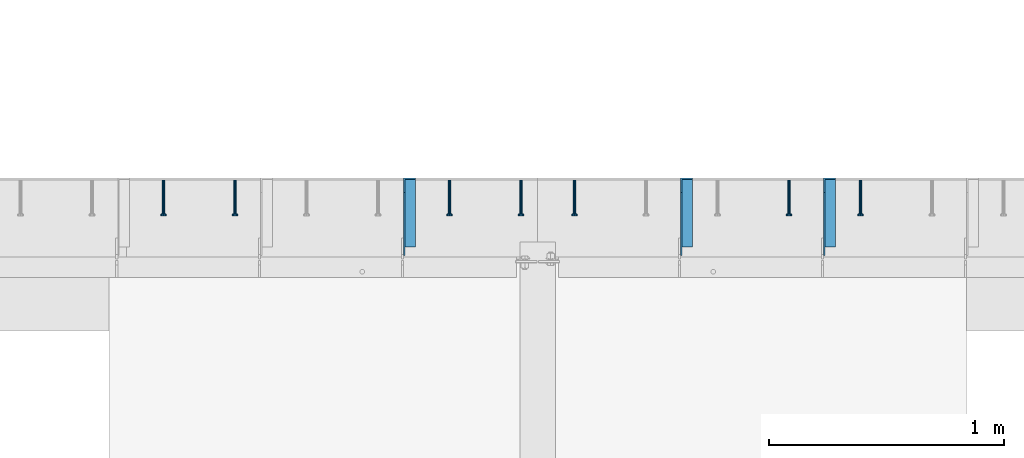
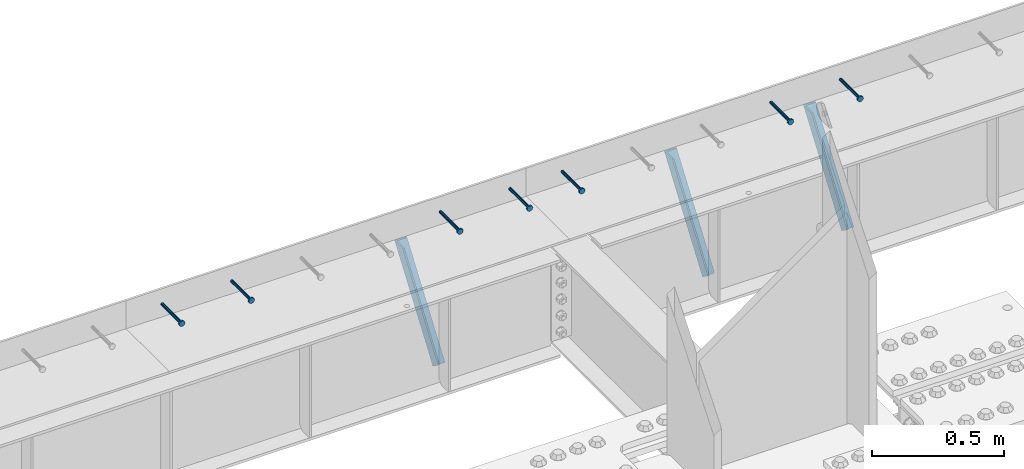
# One storey, part 1347 of 1763: 7 beams, 3 members, 9 elements without a shape of their own.
"""IFC2X3 building model written with IfcOpenShell, lengths in millimetres."""

from ifc_helpers import new_model, si_unit, frame, origin_with_axes, place, context, subcontext, project, spatial, faceted_brep, material, type_object, element, aggregate, save


model = new_model("IFC2X3")

# Units and contexts
model_context = context("Model", 3, precision=1e-05, world=origin_with_axes())
body_context = subcontext(model_context, "Body", "Model", "MODEL_VIEW")
ifc_project = project(units=[si_unit("LENGTHUNIT", "METRE", prefix="MILLI"), si_unit("AREAUNIT", "SQUARE_METRE"), si_unit("VOLUMEUNIT", "CUBIC_METRE"), si_unit("MASSUNIT", "GRAM", prefix="KILO"), si_unit("TIMEUNIT", "SECOND"), si_unit("PLANEANGLEUNIT", "RADIAN"), si_unit("SOLIDANGLEUNIT", "STERADIAN"), si_unit("THERMODYNAMICTEMPERATUREUNIT", "DEGREE_CELSIUS"), si_unit("LUMINOUSINTENSITYUNIT", "LUMEN")], contexts=[model_context])

# Site, building, storey
site_placement = place(None, origin_with_axes())
site = spatial("IfcSite", under=ifc_project, at=site_placement, CompositionType="ELEMENT")
building_placement = place(site_placement, origin_with_axes())
building = spatial("IfcBuilding", under=site, at=building_placement, Name="Undefined", CompositionType="ELEMENT")
storey_placement = place(building_placement, origin_with_axes())
storey = spatial("IfcBuildingStorey", under=building, at=storey_placement, Name="Undefined", CompositionType="ELEMENT", Elevation=0.0)

# Assembly, beam
assembly_1_placement = place(storey_placement, origin_with_axes())
assembly_1 = element("IfcElementAssembly", 1, at=assembly_1_placement, inside=storey, Name="HEADED STUD ANCHOR", AssemblyPlace="NOTDEFINED", PredefinedType="RIGID_FRAME")
ifc_material_1 = material(Name="STEEL/A108")
beam_type = type_object("IfcBeamType", PredefinedType="NOTDEFINED")
beam_1_placement = place(assembly_1_placement, frame((-60218.0747736983, 53984.5250183106, 5264.23140606069), z_axis=(0.0, 0.0, 1.0), x_axis=(0.0, -1.0, 0.0)))
beam_1 = element("IfcBeam", 2, at=beam_1_placement, type_object=beam_type, material=ifc_material_1, Name="HEADED STUD ANCHOR", context=body_context, shape_type="Brep", body=[
    faceted_brep([(0.0, -3.1800000667572, 5.5), (0.0, -5.5, 3.1800000667572), (141.732000000002, -5.5, 3.1800000667572), (141.732000000002, -3.1800000667572, 5.5), (0.0, -6.34999999999491, 1.45519152283669e-11), (141.732000000002, -6.34999990463257, 0.0), (0.0, -5.5, -3.1800000667572), (141.732000000002, -5.5, -3.1800000667572), (0.0, -3.1800000667572, -5.5), (141.732000000002, -3.1800000667572, -5.5), (0.0, 0.0, -6.34999990463257), (141.732000000002, 0.0, -6.34999990463257), (0.0, 3.1800000667572, -5.5), (141.732000000002, 3.1800000667572, -5.5), (0.0, 5.5, -3.1800000667572), (141.732000000002, 5.5, -3.1800000667572), (0.0, 6.34999999999491, -2.91038304567337e-11), (141.732000000002, 6.34999990463257, 0.0), (0.0, 5.5, 3.1800000667572), (141.732000000002, 5.5, 3.1800000667572), (0.0, 3.1800000667572, 5.5), (141.732000000002, 3.1800000667572, 5.5), (0.0, 0.0, 6.34999990463257), (141.732000000002, 0.0, 6.34999990463257), (144.780000000001, -10.9899997711182, 6.34999990463257), (144.780000000001, -6.34000015258789, 10.9899997711182), (144.780000000001, -12.6999998092651, 0.0), (144.780000000001, -10.9899997711182, -6.34999990463257), (144.780000000001, -6.34000015258789, -10.9899997711182), (144.780000000001, 0.0, -12.6899995803833), (144.780000000001, 6.34000015258789, -10.9899997711182), (144.780000000001, 10.9899997711182, -6.34999990463257), (144.780000000001, 12.6999998092651, 0.0), (144.780000000001, 10.9899997711182, 6.34999990463257), (144.780000000001, 6.34000015258789, 10.9899997711182), (144.780000000001, 0.0, 12.6899995803833), (152.400000000001, -10.9899997711182, 6.34999990463257), (152.400000000001, -6.34000015258789, 10.9899997711182), (152.400000000001, -12.6999998092651, 0.0), (152.400000000001, -10.9899997711182, -6.34999990463257), (152.400000000001, -6.34000015258789, -10.9899997711182), (152.400000000001, 0.0, -12.6899995803833), (152.400000000001, 6.34000015258789, -10.9899997711182), (152.400000000001, 10.9899997711182, -6.34999990463257), (152.400000000001, 12.6999998092651, 0.0), (152.400000000001, 10.9899997711182, 6.34999990463257), (152.400000000001, 6.34000015258789, 10.9899997711182), (152.400000000001, 0.0, 12.6899995803833)], [[[0, 1, 2, 3]], [[1, 4, 5, 2]], [[4, 6, 7, 5]], [[6, 8, 9, 7]], [[8, 10, 11, 9]], [[10, 12, 13, 11]], [[12, 14, 15, 13]], [[14, 16, 17, 15]], [[16, 18, 19, 17]], [[18, 20, 21, 19]], [[20, 22, 23, 21]], [[22, 0, 3, 23]], [[22, 20, 18, 16, 14, 12, 10, 8, 6, 4, 1, 0]], [[3, 2, 24, 25]], [[2, 5, 26, 24]], [[5, 7, 27, 26]], [[7, 9, 28, 27]], [[9, 11, 29, 28]], [[11, 13, 30, 29]], [[13, 15, 31, 30]], [[15, 17, 32, 31]], [[17, 19, 33, 32]], [[19, 21, 34, 33]], [[21, 23, 35, 34]], [[23, 3, 25, 35]], [[25, 24, 36, 37]], [[24, 26, 38, 36]], [[26, 27, 39, 38]], [[27, 28, 40, 39]], [[28, 29, 41, 40]], [[29, 30, 42, 41]], [[30, 31, 43, 42]], [[31, 32, 44, 43]], [[32, 33, 45, 44]], [[33, 34, 46, 45]], [[34, 35, 47, 46]], [[35, 25, 37, 47]], [[38, 39, 40, 41, 42, 43, 44, 45, 46, 47, 37, 36]]]),
])
aggregate(assembly_1, [beam_1])

assembly_2_placement = place(storey_placement, origin_with_axes())
assembly_2 = element("IfcElementAssembly", 3, at=assembly_2_placement, inside=storey, Name="HEADED STUD ANCHOR", AssemblyPlace="NOTDEFINED", PredefinedType="RIGID_FRAME")
beam_2_placement = place(assembly_2_placement, frame((-60522.8747736983, 53984.5250183106, 5264.23140606069), z_axis=(0.0, 0.0, 1.0), x_axis=(0.0, -1.0, 0.0)))
beam_2 = element("IfcBeam", 4, at=beam_2_placement, type_object=beam_type, material=ifc_material_1, Name="HEADED STUD ANCHOR", context=body_context, shape_type="Brep", body=[
    faceted_brep([(0.0, -3.1800000667572, 5.5), (0.0, -5.5, 3.1800000667572), (141.732000000002, -5.5, 3.1800000667572), (141.732000000002, -3.1800000667572, 5.5), (0.0, -6.34999999999491, 1.45519152283669e-11), (141.732000000002, -6.34999990463257, 0.0), (0.0, -5.5, -3.1800000667572), (141.732000000002, -5.5, -3.1800000667572), (0.0, -3.1800000667572, -5.5), (141.732000000002, -3.1800000667572, -5.5), (0.0, 0.0, -6.34999990463257), (141.732000000002, 0.0, -6.34999990463257), (0.0, 3.1800000667572, -5.5), (141.732000000002, 3.1800000667572, -5.5), (0.0, 5.5, -3.1800000667572), (141.732000000002, 5.5, -3.1800000667572), (0.0, 6.34999999999491, -2.91038304567337e-11), (141.732000000002, 6.34999990463257, 0.0), (0.0, 5.5, 3.1800000667572), (141.732000000002, 5.5, 3.1800000667572), (0.0, 3.1800000667572, 5.5), (141.732000000002, 3.1800000667572, 5.5), (0.0, 0.0, 6.34999990463257), (141.732000000002, 0.0, 6.34999990463257), (144.780000000001, -10.9899997711182, 6.34999990463257), (144.780000000001, -6.34000015258789, 10.9899997711182), (144.780000000001, -12.6999998092651, 0.0), (144.780000000001, -10.9899997711182, -6.34999990463257), (144.780000000001, -6.34000015258789, -10.9899997711182), (144.780000000001, 0.0, -12.6899995803833), (144.780000000001, 6.34000015258789, -10.9899997711182), (144.780000000001, 10.9899997711182, -6.34999990463257), (144.780000000001, 12.6999998092651, 0.0), (144.780000000001, 10.9899997711182, 6.34999990463257), (144.780000000001, 6.34000015258789, 10.9899997711182), (144.780000000001, 0.0, 12.6899995803833), (152.400000000001, -10.9899997711182, 6.34999990463257), (152.400000000001, -6.34000015258789, 10.9899997711182), (152.400000000001, -12.6999998092651, 0.0), (152.400000000001, -10.9899997711182, -6.34999990463257), (152.400000000001, -6.34000015258789, -10.9899997711182), (152.400000000001, 0.0, -12.6899995803833), (152.400000000001, 6.34000015258789, -10.9899997711182), (152.400000000001, 10.9899997711182, -6.34999990463257), (152.400000000001, 12.6999998092651, 0.0), (152.400000000001, 10.9899997711182, 6.34999990463257), (152.400000000001, 6.34000015258789, 10.9899997711182), (152.400000000001, 0.0, 12.6899995803833)], [[[0, 1, 2, 3]], [[1, 4, 5, 2]], [[4, 6, 7, 5]], [[6, 8, 9, 7]], [[8, 10, 11, 9]], [[10, 12, 13, 11]], [[12, 14, 15, 13]], [[14, 16, 17, 15]], [[16, 18, 19, 17]], [[18, 20, 21, 19]], [[20, 22, 23, 21]], [[22, 0, 3, 23]], [[22, 20, 18, 16, 14, 12, 10, 8, 6, 4, 1, 0]], [[3, 2, 24, 25]], [[2, 5, 26, 24]], [[5, 7, 27, 26]], [[7, 9, 28, 27]], [[9, 11, 29, 28]], [[11, 13, 30, 29]], [[13, 15, 31, 30]], [[15, 17, 32, 31]], [[17, 19, 33, 32]], [[19, 21, 34, 33]], [[21, 23, 35, 34]], [[23, 3, 25, 35]], [[25, 24, 36, 37]], [[24, 26, 38, 36]], [[26, 27, 39, 38]], [[27, 28, 40, 39]], [[28, 29, 41, 40]], [[29, 30, 42, 41]], [[30, 31, 43, 42]], [[31, 32, 44, 43]], [[32, 33, 45, 44]], [[33, 34, 46, 45]], [[34, 35, 47, 46]], [[35, 25, 37, 47]], [[38, 39, 40, 41, 42, 43, 44, 45, 46, 47, 37, 36]]]),
])
aggregate(assembly_2, [beam_2])

assembly_3_placement = place(storey_placement, origin_with_axes())
assembly_3 = element("IfcElementAssembly", 5, at=assembly_3_placement, inside=storey, Name="HEADED STUD ANCHOR", AssemblyPlace="NOTDEFINED", PredefinedType="RIGID_FRAME")
beam_3_placement = place(assembly_3_placement, frame((-61437.2747736983, 53984.5250183106, 5264.23140606069), z_axis=(0.0, 0.0, 1.0), x_axis=(0.0, -1.0, 0.0)))
beam_3 = element("IfcBeam", 6, at=beam_3_placement, type_object=beam_type, material=ifc_material_1, Name="HEADED STUD ANCHOR", context=body_context, shape_type="Brep", body=[
    faceted_brep([(0.0, -3.1800000667572, 5.5), (0.0, -5.5, 3.1800000667572), (141.732000000002, -5.5, 3.1800000667572), (141.732000000002, -3.1800000667572, 5.5), (0.0, -6.34999999999491, 1.45519152283669e-11), (141.732000000002, -6.34999990463257, 0.0), (0.0, -5.5, -3.1800000667572), (141.732000000002, -5.5, -3.1800000667572), (0.0, -3.1800000667572, -5.5), (141.732000000002, -3.1800000667572, -5.5), (0.0, 0.0, -6.34999990463257), (141.732000000002, 0.0, -6.34999990463257), (0.0, 3.1800000667572, -5.5), (141.732000000002, 3.1800000667572, -5.5), (0.0, 5.5, -3.1800000667572), (141.732000000002, 5.5, -3.1800000667572), (0.0, 6.34999999999491, -2.91038304567337e-11), (141.732000000002, 6.34999990463257, 0.0), (0.0, 5.5, 3.1800000667572), (141.732000000002, 5.5, 3.1800000667572), (0.0, 3.1800000667572, 5.5), (141.732000000002, 3.1800000667572, 5.5), (0.0, 0.0, 6.34999990463257), (141.732000000002, 0.0, 6.34999990463257), (144.780000000001, -10.9899997711182, 6.34999990463257), (144.780000000001, -6.34000015258789, 10.9899997711182), (144.780000000001, -12.6999998092651, 0.0), (144.780000000001, -10.9899997711182, -6.34999990463257), (144.780000000001, -6.34000015258789, -10.9899997711182), (144.780000000001, 0.0, -12.6899995803833), (144.780000000001, 6.34000015258789, -10.9899997711182), (144.780000000001, 10.9899997711182, -6.34999990463257), (144.780000000001, 12.6999998092651, 0.0), (144.780000000001, 10.9899997711182, 6.34999990463257), (144.780000000001, 6.34000015258789, 10.9899997711182), (144.780000000001, 0.0, 12.6899995803833), (152.400000000001, -10.9899997711182, 6.34999990463257), (152.400000000001, -6.34000015258789, 10.9899997711182), (152.400000000001, -12.6999998092651, 0.0), (152.400000000001, -10.9899997711182, -6.34999990463257), (152.400000000001, -6.34000015258789, -10.9899997711182), (152.400000000001, 0.0, -12.6899995803833), (152.400000000001, 6.34000015258789, -10.9899997711182), (152.400000000001, 10.9899997711182, -6.34999990463257), (152.400000000001, 12.6999998092651, 0.0), (152.400000000001, 10.9899997711182, 6.34999990463257), (152.400000000001, 6.34000015258789, 10.9899997711182), (152.400000000001, 0.0, 12.6899995803833)], [[[0, 1, 2, 3]], [[1, 4, 5, 2]], [[4, 6, 7, 5]], [[6, 8, 9, 7]], [[8, 10, 11, 9]], [[10, 12, 13, 11]], [[12, 14, 15, 13]], [[14, 16, 17, 15]], [[16, 18, 19, 17]], [[18, 20, 21, 19]], [[20, 22, 23, 21]], [[22, 0, 3, 23]], [[22, 20, 18, 16, 14, 12, 10, 8, 6, 4, 1, 0]], [[3, 2, 24, 25]], [[2, 5, 26, 24]], [[5, 7, 27, 26]], [[7, 9, 28, 27]], [[9, 11, 29, 28]], [[11, 13, 30, 29]], [[13, 15, 31, 30]], [[15, 17, 32, 31]], [[17, 19, 33, 32]], [[19, 21, 34, 33]], [[21, 23, 35, 34]], [[23, 3, 25, 35]], [[25, 24, 36, 37]], [[24, 26, 38, 36]], [[26, 27, 39, 38]], [[27, 28, 40, 39]], [[28, 29, 41, 40]], [[29, 30, 42, 41]], [[30, 31, 43, 42]], [[31, 32, 44, 43]], [[32, 33, 45, 44]], [[33, 34, 46, 45]], [[34, 35, 47, 46]], [[35, 25, 37, 47]], [[38, 39, 40, 41, 42, 43, 44, 45, 46, 47, 37, 36]]]),
])
aggregate(assembly_3, [beam_3])

assembly_4_placement = place(storey_placement, origin_with_axes())
assembly_4 = element("IfcElementAssembly", 7, at=assembly_4_placement, inside=storey, Name="HEADED STUD ANCHOR", AssemblyPlace="NOTDEFINED", PredefinedType="RIGID_FRAME")
beam_4_placement = place(assembly_4_placement, frame((-61665.8747736983, 53984.5250183106, 5264.23140606069), z_axis=(0.0, 0.0, 1.0), x_axis=(0.0, -1.0, 0.0)))
beam_4 = element("IfcBeam", 8, at=beam_4_placement, type_object=beam_type, material=ifc_material_1, Name="HEADED STUD ANCHOR", context=body_context, shape_type="Brep", body=[
    faceted_brep([(0.0, -3.1800000667572, 5.5), (0.0, -5.5, 3.1800000667572), (141.732000000002, -5.5, 3.1800000667572), (141.732000000002, -3.1800000667572, 5.5), (0.0, -6.34999999999491, 1.45519152283669e-11), (141.732000000002, -6.34999990463257, 0.0), (0.0, -5.5, -3.1800000667572), (141.732000000002, -5.5, -3.1800000667572), (0.0, -3.1800000667572, -5.5), (141.732000000002, -3.1800000667572, -5.5), (0.0, 0.0, -6.34999990463257), (141.732000000002, 0.0, -6.34999990463257), (0.0, 3.1800000667572, -5.5), (141.732000000002, 3.1800000667572, -5.5), (0.0, 5.5, -3.1800000667572), (141.732000000002, 5.5, -3.1800000667572), (0.0, 6.34999999999491, -2.91038304567337e-11), (141.732000000002, 6.34999990463257, 0.0), (0.0, 5.5, 3.1800000667572), (141.732000000002, 5.5, 3.1800000667572), (0.0, 3.1800000667572, 5.5), (141.732000000002, 3.1800000667572, 5.5), (0.0, 0.0, 6.34999990463257), (141.732000000002, 0.0, 6.34999990463257), (144.780000000001, -10.9899997711182, 6.34999990463257), (144.780000000001, -6.34000015258789, 10.9899997711182), (144.780000000001, -12.6999998092651, 0.0), (144.780000000001, -10.9899997711182, -6.34999990463257), (144.780000000001, -6.34000015258789, -10.9899997711182), (144.780000000001, 0.0, -12.6899995803833), (144.780000000001, 6.34000015258789, -10.9899997711182), (144.780000000001, 10.9899997711182, -6.34999990463257), (144.780000000001, 12.6999998092651, 0.0), (144.780000000001, 10.9899997711182, 6.34999990463257), (144.780000000001, 6.34000015258789, 10.9899997711182), (144.780000000001, 0.0, 12.6899995803833), (152.400000000001, -10.9899997711182, 6.34999990463257), (152.400000000001, -6.34000015258789, 10.9899997711182), (152.400000000001, -12.6999998092651, 0.0), (152.400000000001, -10.9899997711182, -6.34999990463257), (152.400000000001, -6.34000015258789, -10.9899997711182), (152.400000000001, 0.0, -12.6899995803833), (152.400000000001, 6.34000015258789, -10.9899997711182), (152.400000000001, 10.9899997711182, -6.34999990463257), (152.400000000001, 12.6999998092651, 0.0), (152.400000000001, 10.9899997711182, 6.34999990463257), (152.400000000001, 6.34000015258789, 10.9899997711182), (152.400000000001, 0.0, 12.6899995803833)], [[[0, 1, 2, 3]], [[1, 4, 5, 2]], [[4, 6, 7, 5]], [[6, 8, 9, 7]], [[8, 10, 11, 9]], [[10, 12, 13, 11]], [[12, 14, 15, 13]], [[14, 16, 17, 15]], [[16, 18, 19, 17]], [[18, 20, 21, 19]], [[20, 22, 23, 21]], [[22, 0, 3, 23]], [[22, 20, 18, 16, 14, 12, 10, 8, 6, 4, 1, 0]], [[3, 2, 24, 25]], [[2, 5, 26, 24]], [[5, 7, 27, 26]], [[7, 9, 28, 27]], [[9, 11, 29, 28]], [[11, 13, 30, 29]], [[13, 15, 31, 30]], [[15, 17, 32, 31]], [[17, 19, 33, 32]], [[19, 21, 34, 33]], [[21, 23, 35, 34]], [[23, 3, 25, 35]], [[25, 24, 36, 37]], [[24, 26, 38, 36]], [[26, 27, 39, 38]], [[27, 28, 40, 39]], [[28, 29, 41, 40]], [[29, 30, 42, 41]], [[30, 31, 43, 42]], [[31, 32, 44, 43]], [[32, 33, 45, 44]], [[33, 34, 46, 45]], [[34, 35, 47, 46]], [[35, 25, 37, 47]], [[38, 39, 40, 41, 42, 43, 44, 45, 46, 47, 37, 36]]]),
])
aggregate(assembly_4, [beam_4])

assembly_5_placement = place(storey_placement, origin_with_axes())
assembly_5 = element("IfcElementAssembly", 9, at=assembly_5_placement, inside=storey, Name="HEADED STUD ANCHOR", AssemblyPlace="NOTDEFINED", PredefinedType="RIGID_FRAME")
beam_5_placement = place(assembly_5_placement, frame((-61970.6747736984, 53984.5250183106, 5264.23140606069), z_axis=(0.0, 0.0, 1.0), x_axis=(0.0, -1.0, 0.0)))
beam_5 = element("IfcBeam", 10, at=beam_5_placement, type_object=beam_type, material=ifc_material_1, Name="HEADED STUD ANCHOR", context=body_context, shape_type="Brep", body=[
    faceted_brep([(0.0, -3.1800000667572, 5.5), (0.0, -5.5, 3.1800000667572), (141.732000000002, -5.5, 3.1800000667572), (141.732000000002, -3.1800000667572, 5.5), (0.0, -6.34999999999491, 1.45519152283669e-11), (141.732000000002, -6.34999990463257, 0.0), (0.0, -5.5, -3.1800000667572), (141.732000000002, -5.5, -3.1800000667572), (0.0, -3.1800000667572, -5.5), (141.732000000002, -3.1800000667572, -5.5), (0.0, 0.0, -6.34999990463257), (141.732000000002, 0.0, -6.34999990463257), (0.0, 3.1800000667572, -5.5), (141.732000000002, 3.1800000667572, -5.5), (0.0, 5.5, -3.1800000667572), (141.732000000002, 5.5, -3.1800000667572), (0.0, 6.34999999999491, -2.91038304567337e-11), (141.732000000002, 6.34999990463257, 0.0), (0.0, 5.5, 3.1800000667572), (141.732000000002, 5.5, 3.1800000667572), (0.0, 3.1800000667572, 5.5), (141.732000000002, 3.1800000667572, 5.5), (0.0, 0.0, 6.34999990463257), (141.732000000002, 0.0, 6.34999990463257), (144.780000000001, -10.9899997711182, 6.34999990463257), (144.780000000001, -6.34000015258789, 10.9899997711182), (144.780000000001, -12.6999998092651, 0.0), (144.780000000001, -10.9899997711182, -6.34999990463257), (144.780000000001, -6.34000015258789, -10.9899997711182), (144.780000000001, 0.0, -12.6899995803833), (144.780000000001, 6.34000015258789, -10.9899997711182), (144.780000000001, 10.9899997711182, -6.34999990463257), (144.780000000001, 12.6999998092651, 0.0), (144.780000000001, 10.9899997711182, 6.34999990463257), (144.780000000001, 6.34000015258789, 10.9899997711182), (144.780000000001, 0.0, 12.6899995803833), (152.400000000001, -10.9899997711182, 6.34999990463257), (152.400000000001, -6.34000015258789, 10.9899997711182), (152.400000000001, -12.6999998092651, 0.0), (152.400000000001, -10.9899997711182, -6.34999990463257), (152.400000000001, -6.34000015258789, -10.9899997711182), (152.400000000001, 0.0, -12.6899995803833), (152.400000000001, 6.34000015258789, -10.9899997711182), (152.400000000001, 10.9899997711182, -6.34999990463257), (152.400000000001, 12.6999998092651, 0.0), (152.400000000001, 10.9899997711182, 6.34999990463257), (152.400000000001, 6.34000015258789, 10.9899997711182), (152.400000000001, 0.0, 12.6899995803833)], [[[0, 1, 2, 3]], [[1, 4, 5, 2]], [[4, 6, 7, 5]], [[6, 8, 9, 7]], [[8, 10, 11, 9]], [[10, 12, 13, 11]], [[12, 14, 15, 13]], [[14, 16, 17, 15]], [[16, 18, 19, 17]], [[18, 20, 21, 19]], [[20, 22, 23, 21]], [[22, 0, 3, 23]], [[22, 20, 18, 16, 14, 12, 10, 8, 6, 4, 1, 0]], [[3, 2, 24, 25]], [[2, 5, 26, 24]], [[5, 7, 27, 26]], [[7, 9, 28, 27]], [[9, 11, 29, 28]], [[11, 13, 30, 29]], [[13, 15, 31, 30]], [[15, 17, 32, 31]], [[17, 19, 33, 32]], [[19, 21, 34, 33]], [[21, 23, 35, 34]], [[23, 3, 25, 35]], [[25, 24, 36, 37]], [[24, 26, 38, 36]], [[26, 27, 39, 38]], [[27, 28, 40, 39]], [[28, 29, 41, 40]], [[29, 30, 42, 41]], [[30, 31, 43, 42]], [[31, 32, 44, 43]], [[32, 33, 45, 44]], [[33, 34, 46, 45]], [[34, 35, 47, 46]], [[35, 25, 37, 47]], [[38, 39, 40, 41, 42, 43, 44, 45, 46, 47, 37, 36]]]),
])
aggregate(assembly_5, [beam_5])

assembly_6_placement = place(storey_placement, origin_with_axes())
assembly_6 = element("IfcElementAssembly", 11, at=assembly_6_placement, inside=storey, Name="HEADED STUD ANCHOR", AssemblyPlace="NOTDEFINED", PredefinedType="RIGID_FRAME")
beam_6_placement = place(assembly_6_placement, frame((-62885.0747736983, 53984.5250183106, 5264.23140606069), z_axis=(0.0, 0.0, 1.0), x_axis=(0.0, -1.0, 0.0)))
beam_6 = element("IfcBeam", 12, at=beam_6_placement, type_object=beam_type, material=ifc_material_1, Name="HEADED STUD ANCHOR", context=body_context, shape_type="Brep", body=[
    faceted_brep([(0.0, -3.1800000667572, 5.5), (0.0, -5.5, 3.1800000667572), (141.732000000002, -5.5, 3.1800000667572), (141.732000000002, -3.1800000667572, 5.5), (0.0, -6.34999999999491, 1.45519152283669e-11), (141.732000000002, -6.34999990463257, 0.0), (0.0, -5.5, -3.1800000667572), (141.732000000002, -5.5, -3.1800000667572), (0.0, -3.1800000667572, -5.5), (141.732000000002, -3.1800000667572, -5.5), (0.0, 0.0, -6.34999990463257), (141.732000000002, 0.0, -6.34999990463257), (0.0, 3.1800000667572, -5.5), (141.732000000002, 3.1800000667572, -5.5), (0.0, 5.5, -3.1800000667572), (141.732000000002, 5.5, -3.1800000667572), (0.0, 6.34999999999491, -2.91038304567337e-11), (141.732000000002, 6.34999990463257, 0.0), (0.0, 5.5, 3.1800000667572), (141.732000000002, 5.5, 3.1800000667572), (0.0, 3.1800000667572, 5.5), (141.732000000002, 3.1800000667572, 5.5), (0.0, 0.0, 6.34999990463257), (141.732000000002, 0.0, 6.34999990463257), (144.780000000001, -10.9899997711182, 6.34999990463257), (144.780000000001, -6.34000015258789, 10.9899997711182), (144.780000000001, -12.6999998092651, 0.0), (144.780000000001, -10.9899997711182, -6.34999990463257), (144.780000000001, -6.34000015258789, -10.9899997711182), (144.780000000001, 0.0, -12.6899995803833), (144.780000000001, 6.34000015258789, -10.9899997711182), (144.780000000001, 10.9899997711182, -6.34999990463257), (144.780000000001, 12.6999998092651, 0.0), (144.780000000001, 10.9899997711182, 6.34999990463257), (144.780000000001, 6.34000015258789, 10.9899997711182), (144.780000000001, 0.0, 12.6899995803833), (152.400000000001, -10.9899997711182, 6.34999990463257), (152.400000000001, -6.34000015258789, 10.9899997711182), (152.400000000001, -12.6999998092651, 0.0), (152.400000000001, -10.9899997711182, -6.34999990463257), (152.400000000001, -6.34000015258789, -10.9899997711182), (152.400000000001, 0.0, -12.6899995803833), (152.400000000001, 6.34000015258789, -10.9899997711182), (152.400000000001, 10.9899997711182, -6.34999990463257), (152.400000000001, 12.6999998092651, 0.0), (152.400000000001, 10.9899997711182, 6.34999990463257), (152.400000000001, 6.34000015258789, 10.9899997711182), (152.400000000001, 0.0, 12.6899995803833)], [[[0, 1, 2, 3]], [[1, 4, 5, 2]], [[4, 6, 7, 5]], [[6, 8, 9, 7]], [[8, 10, 11, 9]], [[10, 12, 13, 11]], [[12, 14, 15, 13]], [[14, 16, 17, 15]], [[16, 18, 19, 17]], [[18, 20, 21, 19]], [[20, 22, 23, 21]], [[22, 0, 3, 23]], [[22, 20, 18, 16, 14, 12, 10, 8, 6, 4, 1, 0]], [[3, 2, 24, 25]], [[2, 5, 26, 24]], [[5, 7, 27, 26]], [[7, 9, 28, 27]], [[9, 11, 29, 28]], [[11, 13, 30, 29]], [[13, 15, 31, 30]], [[15, 17, 32, 31]], [[17, 19, 33, 32]], [[19, 21, 34, 33]], [[21, 23, 35, 34]], [[23, 3, 25, 35]], [[25, 24, 36, 37]], [[24, 26, 38, 36]], [[26, 27, 39, 38]], [[27, 28, 40, 39]], [[28, 29, 41, 40]], [[29, 30, 42, 41]], [[30, 31, 43, 42]], [[31, 32, 44, 43]], [[32, 33, 45, 44]], [[33, 34, 46, 45]], [[34, 35, 47, 46]], [[35, 25, 37, 47]], [[38, 39, 40, 41, 42, 43, 44, 45, 46, 47, 37, 36]]]),
])
aggregate(assembly_6, [beam_6])

assembly_7_placement = place(storey_placement, origin_with_axes())
assembly_7 = element("IfcElementAssembly", 13, at=assembly_7_placement, inside=storey, Name="HEADED STUD ANCHOR", AssemblyPlace="NOTDEFINED", PredefinedType="RIGID_FRAME")
beam_7_placement = place(assembly_7_placement, frame((-63189.8747736983, 53984.5250183106, 5264.23140606069), z_axis=(0.0, 0.0, 1.0), x_axis=(0.0, -1.0, 0.0)))
beam_7 = element("IfcBeam", 14, at=beam_7_placement, type_object=beam_type, material=ifc_material_1, Name="HEADED STUD ANCHOR", context=body_context, shape_type="Brep", body=[
    faceted_brep([(0.0, -3.1800000667572, 5.5), (0.0, -5.5, 3.1800000667572), (141.732000000002, -5.5, 3.1800000667572), (141.732000000002, -3.1800000667572, 5.5), (0.0, -6.34999999999491, 1.45519152283669e-11), (141.732000000002, -6.34999990463257, 0.0), (0.0, -5.5, -3.1800000667572), (141.732000000002, -5.5, -3.1800000667572), (0.0, -3.1800000667572, -5.5), (141.732000000002, -3.1800000667572, -5.5), (0.0, 0.0, -6.34999990463257), (141.732000000002, 0.0, -6.34999990463257), (0.0, 3.1800000667572, -5.5), (141.732000000002, 3.1800000667572, -5.5), (0.0, 5.5, -3.1800000667572), (141.732000000002, 5.5, -3.1800000667572), (0.0, 6.34999999999491, -2.91038304567337e-11), (141.732000000002, 6.34999990463257, 0.0), (0.0, 5.5, 3.1800000667572), (141.732000000002, 5.5, 3.1800000667572), (0.0, 3.1800000667572, 5.5), (141.732000000002, 3.1800000667572, 5.5), (0.0, 0.0, 6.34999990463257), (141.732000000002, 0.0, 6.34999990463257), (144.780000000001, -10.9899997711182, 6.34999990463257), (144.780000000001, -6.34000015258789, 10.9899997711182), (144.780000000001, -12.6999998092651, 0.0), (144.780000000001, -10.9899997711182, -6.34999990463257), (144.780000000001, -6.34000015258789, -10.9899997711182), (144.780000000001, 0.0, -12.6899995803833), (144.780000000001, 6.34000015258789, -10.9899997711182), (144.780000000001, 10.9899997711182, -6.34999990463257), (144.780000000001, 12.6999998092651, 0.0), (144.780000000001, 10.9899997711182, 6.34999990463257), (144.780000000001, 6.34000015258789, 10.9899997711182), (144.780000000001, 0.0, 12.6899995803833), (152.400000000001, -10.9899997711182, 6.34999990463257), (152.400000000001, -6.34000015258789, 10.9899997711182), (152.400000000001, -12.6999998092651, 0.0), (152.400000000001, -10.9899997711182, -6.34999990463257), (152.400000000001, -6.34000015258789, -10.9899997711182), (152.400000000001, 0.0, -12.6899995803833), (152.400000000001, 6.34000015258789, -10.9899997711182), (152.400000000001, 10.9899997711182, -6.34999990463257), (152.400000000001, 12.6999998092651, 0.0), (152.400000000001, 10.9899997711182, 6.34999990463257), (152.400000000001, 6.34000015258789, 10.9899997711182), (152.400000000001, 0.0, 12.6899995803833)], [[[0, 1, 2, 3]], [[1, 4, 5, 2]], [[4, 6, 7, 5]], [[6, 8, 9, 7]], [[8, 10, 11, 9]], [[10, 12, 13, 11]], [[12, 14, 15, 13]], [[14, 16, 17, 15]], [[16, 18, 19, 17]], [[18, 20, 21, 19]], [[20, 22, 23, 21]], [[22, 0, 3, 23]], [[22, 20, 18, 16, 14, 12, 10, 8, 6, 4, 1, 0]], [[3, 2, 24, 25]], [[2, 5, 26, 24]], [[5, 7, 27, 26]], [[7, 9, 28, 27]], [[9, 11, 29, 28]], [[11, 13, 30, 29]], [[13, 15, 31, 30]], [[15, 17, 32, 31]], [[17, 19, 33, 32]], [[19, 21, 34, 33]], [[21, 23, 35, 34]], [[23, 3, 25, 35]], [[25, 24, 36, 37]], [[24, 26, 38, 36]], [[26, 27, 39, 38]], [[27, 28, 40, 39]], [[28, 29, 41, 40]], [[29, 30, 42, 41]], [[30, 31, 43, 42]], [[31, 32, 44, 43]], [[32, 33, 45, 44]], [[33, 34, 46, 45]], [[34, 35, 47, 46]], [[35, 25, 37, 47]], [[38, 39, 40, 41, 42, 43, 44, 45, 46, 47, 37, 36]]]),
])
aggregate(assembly_7, [beam_7])

# Assembly, members
assembly_8_placement = place(storey_placement, origin_with_axes())
assembly_8 = element("IfcElementAssembly", 15, at=assembly_8_placement, inside=storey, Name="BEAM", AssemblyPlace="NOTDEFINED", PredefinedType="RIGID_FRAME")
ifc_material_2 = material(Name="STEEL/A36")
member_type = type_object("IfcMemberType", Name="L2X2X1/4", PredefinedType="NOTDEFINED")
member_1_placement = place(assembly_8_placement, frame((-60349.8372736984, 53682.7083833991, 4801.55161052498), z_axis=(0.0, -0.814117947745209, 0.580699549818259), x_axis=(0.0, 0.58069954981826, 0.814117947745209)))
member_1 = element("IfcMember", 16, at=member_1_placement, type_object=member_type, material=ifc_material_2, Name="ANGLE", ObjectType="L2X2X1/4", context=body_context, shape_type="Brep", body=[
    faceted_brep([(-1.45519152283669e-11, 25.4000000000015, -25.3999999999869), (1.45519152283669e-11, 25.4000000000015, 25.3999999999796), (464.304493432646, 25.4000000000015, 25.3999999991429), (500.539460322936, 25.4000000000015, -25.4000000009546), (1.45519152283669e-11, 19.0499999999993, 25.3999999999796), (464.304493432646, 19.0500000000029, 25.3999999991429), (-7.27595761418343e-12, 19.0499999999993, -19.0499999999956), (496.010089461648, 19.0500000000029, -19.0500000009415), (-7.27595761418343e-12, -25.4000000000015, -19.0499999999956), (496.010089461648, -25.4000000000015, -19.0500000009415), (-1.45519152283669e-11, -25.4000000000015, -25.3999999999869), (500.539460322936, -25.4000000000015, -25.4000000009546)], [[[0, 1, 2, 3]], [[1, 4, 5, 2]], [[4, 6, 7, 5]], [[6, 8, 9, 7]], [[8, 10, 11, 9]], [[10, 0, 3, 11]], [[5, 7, 9, 11, 3, 2]], [[10, 8, 6, 4, 1, 0]]]),
])
member_2_placement = place(assembly_8_placement, frame((-60959.4372736984, 53682.7083833991, 4801.55161052498), z_axis=(0.0, -0.814117947745209, 0.580699549818259), x_axis=(0.0, 0.58069954981826, 0.814117947745209)))
member_2 = element("IfcMember", 17, at=member_2_placement, type_object=member_type, material=ifc_material_2, Name="ANGLE", ObjectType="L2X2X1/4", context=body_context, shape_type="Brep", body=[
    faceted_brep([(-1.45519152283669e-11, 25.4000000000015, -25.3999999999869), (1.45519152283669e-11, 25.4000000000015, 25.3999999999796), (464.304493432646, 25.4000000000015, 25.3999999991429), (500.539460322936, 25.4000000000015, -25.4000000009546), (1.45519152283669e-11, 19.0499999999993, 25.3999999999796), (464.304493432646, 19.0500000000029, 25.3999999991429), (-7.27595761418343e-12, 19.0499999999993, -19.0499999999956), (496.010089461648, 19.0500000000029, -19.0500000009415), (-7.27595761418343e-12, -25.4000000000015, -19.0499999999956), (496.010089461648, -25.4000000000015, -19.0500000009415), (-1.45519152283669e-11, -25.4000000000015, -25.3999999999869), (500.539460322936, -25.4000000000015, -25.4000000009546)], [[[0, 1, 2, 3]], [[1, 4, 5, 2]], [[4, 6, 7, 5]], [[6, 8, 9, 7]], [[8, 10, 11, 9]], [[10, 0, 3, 11]], [[5, 7, 9, 11, 3, 2]], [[10, 8, 6, 4, 1, 0]]]),
])
aggregate(assembly_8, [member_1, member_2])

# Assembly, member
assembly_9_placement = place(storey_placement, origin_with_axes())
assembly_9 = element("IfcElementAssembly", 18, at=assembly_9_placement, inside=storey, Name="BEAM", AssemblyPlace="NOTDEFINED", PredefinedType="RIGID_FRAME")
member_3_placement = place(assembly_9_placement, frame((-62140.5372736983, 53682.7083833994, 4801.55161052493), z_axis=(0.0, -0.814117947745209, 0.580699549818259), x_axis=(0.0, 0.58069954981826, 0.814117947745209)))
member_3 = element("IfcMember", 19, at=member_3_placement, type_object=member_type, material=ifc_material_2, Name="ANGLE", ObjectType="L2X2X1/4", context=body_context, shape_type="Brep", body=[
    faceted_brep([(-1.45519152283669e-11, 25.4000000000015, -25.3999999999869), (1.45519152283669e-11, 25.4000000000015, 25.3999999999796), (464.304493432646, 25.4000000000015, 25.3999999991429), (500.539460322936, 25.4000000000015, -25.4000000009546), (1.45519152283669e-11, 19.0499999999993, 25.3999999999796), (464.304493432646, 19.0500000000029, 25.3999999991429), (-7.27595761418343e-12, 19.0499999999993, -19.0499999999956), (496.010089461648, 19.0500000000029, -19.0500000009415), (-7.27595761418343e-12, -25.4000000000015, -19.0499999999956), (496.010089461648, -25.4000000000015, -19.0500000009415), (-1.45519152283669e-11, -25.4000000000015, -25.3999999999869), (500.539460322936, -25.4000000000015, -25.4000000009546)], [[[0, 1, 2, 3]], [[1, 4, 5, 2]], [[4, 6, 7, 5]], [[6, 8, 9, 7]], [[8, 10, 11, 9]], [[10, 0, 3, 11]], [[5, 7, 9, 11, 3, 2]], [[10, 8, 6, 4, 1, 0]]]),
])
aggregate(assembly_9, [member_3])

save(model, "model.ifc")
